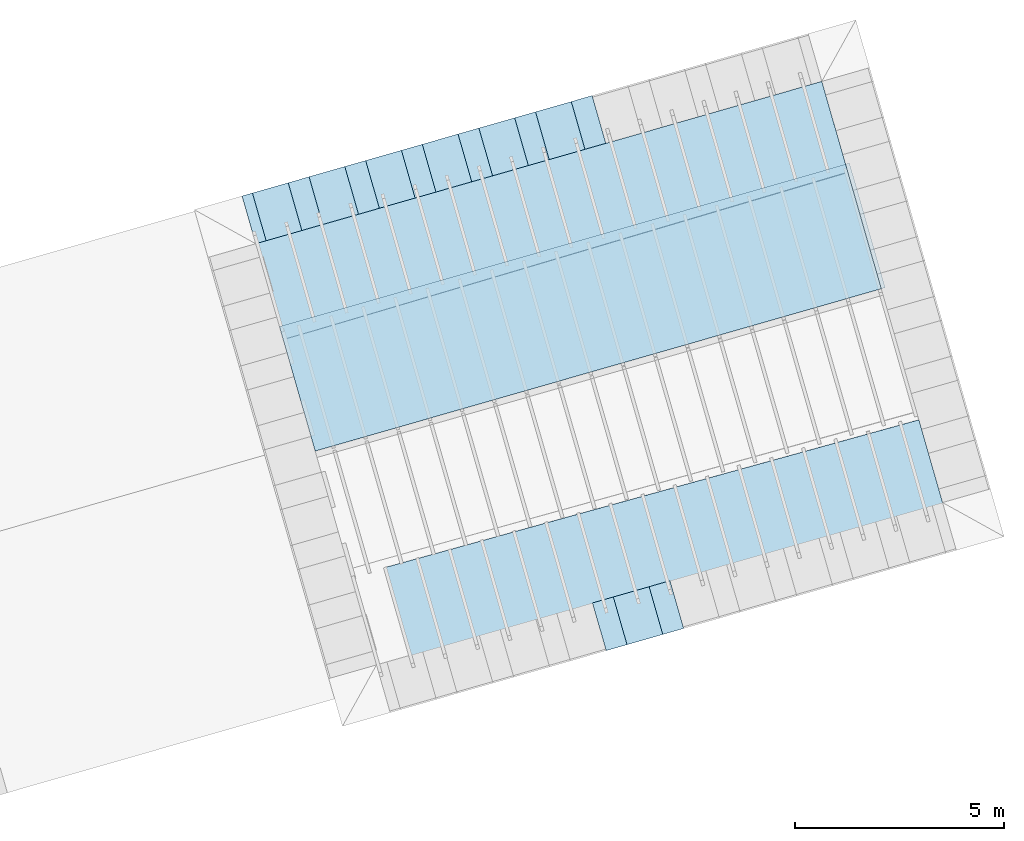
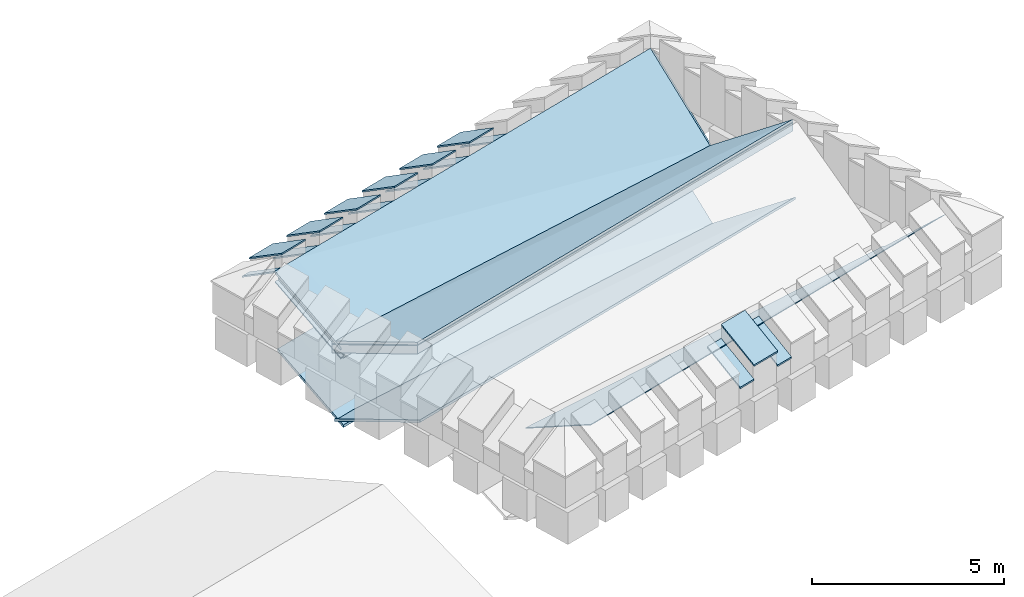
# One storey, part 2 of 10: 24 roofs.
"""IFC4 building model written with IfcOpenShell, lengths in metres."""

from ifc_helpers import new_model, entity, si_unit, converted_unit, derived_unit, direction, frame, origin_with_axes, place, context, subcontext, project, spatial, polygons, material, type_object, element, save


model = new_model("IFC4")

# Units and contexts
model_context = context("Model", 3, precision=1e-05, world=origin_with_axes(), true_north=direction((0.0, 1.0)))
body_context = subcontext(model_context, "Body", "Model", "MODEL_VIEW")
ifc_project = project(units=[si_unit("LENGTHUNIT", "METRE"), si_unit("AREAUNIT", "SQUARE_METRE"), si_unit("VOLUMEUNIT", "CUBIC_METRE"), converted_unit("PLANEANGLEUNIT", "DEGREE", entity("IfcPlaneAngleMeasure", 0.0174532925199433), si_unit("PLANEANGLEUNIT", "RADIAN"), dimensions=[0, 0, 0, 0, 0, 0, 0]), converted_unit("TIMEUNIT", "Year", entity("IfcTimeMeasure", 31557600.0), si_unit("TIMEUNIT", "SECOND"), dimensions=[0, 0, 1, 0, 0, 0, 0]), si_unit("MASSUNIT", "GRAM", prefix="KILO"), si_unit("THERMODYNAMICTEMPERATUREUNIT", "DEGREE_CELSIUS"), si_unit("LUMINOUSINTENSITYUNIT", "LUMEN"), si_unit("ENERGYUNIT", "JOULE", prefix="MEGA"), derived_unit("THERMALCONDUCTANCEUNIT", [(si_unit("POWERUNIT", "WATT"), 1), (si_unit("LENGTHUNIT", "METRE"), -1), (si_unit("THERMODYNAMICTEMPERATUREUNIT", "KELVIN"), -1)]), derived_unit("SPECIFICHEATCAPACITYUNIT", [(si_unit("ENERGYUNIT", "JOULE"), 1), (si_unit("MASSUNIT", "GRAM", prefix="KILO"), -1), (si_unit("THERMODYNAMICTEMPERATUREUNIT", "KELVIN"), -1)]), derived_unit("MASSDENSITYUNIT", [(si_unit("MASSUNIT", "GRAM", prefix="KILO"), 1), (si_unit("VOLUMEUNIT", "CUBIC_METRE"), -1)])], contexts=[model_context])

# Site, building, storey
site_placement = place(None, frame((0.0, 0.0, 0.0), z_axis=(0.0, 0.0, 1.0), x_axis=(0.9612616959383189, 0.2756373558169991, 0.0)))
site = spatial("IfcSite", under=ifc_project, at=site_placement, CompositionType="ELEMENT")
building_placement = place(site_placement, origin_with_axes())
building = spatial("IfcBuilding", under=site, at=building_placement, CompositionType="ELEMENT")
storey_placement = place(building_placement, frame((0.0, 0.0, 11.0), z_axis=(0.0, 0.0, 1.0), x_axis=(1.0, 0.0, 0.0)))
storey = spatial("IfcBuildingStorey", under=building, at=storey_placement, Name="Dach", CompositionType="ELEMENT", Elevation=11.0)

# Roofs
ifc_material_1 = material(Name="schwarz")
roof_type_1 = type_object("IfcRoofType", Name="schwarz 43", PredefinedType="NOTDEFINED")
roof_1_placement = place(storey_placement, frame((17.51182302562153, 19.30664613480766, 1.213699999999999), z_axis=(0.0, 0.0, 1.0), x_axis=(-1.0, 0.0, 0.0)))
element("IfcRoof", 1, at=roof_1_placement, inside=storey, type_object=roof_type_1, material=ifc_material_1, Name="Dach-057", PredefinedType="NOTDEFINED", context=body_context, shape_type="Tessellation", body=[
    polygons([(0.8900025616952547, -0.03772698703644295, 0.0271446603798573), (0.8900025616952547, 1.149999999999999, 0.7466800857374327), (0.0, 1.149999999999999, 0.7466800857374327), (0.0, -0.03772698703644295, 0.0271446603798573), (0.8900025620847707, -0.03772698691103216, -0.0228553396740967), (0.8900025620847707, 1.150000000333105, 0.6966800858093016), (3.516440472139948e-10, 1.150000000333105, 0.6966800858093016), (3.516440472139948e-10, -0.03772698691103216, -0.0228553396740967)], [[[1, 2, 3, 4]], [[2, 1, 5, 6]], [[3, 2, 6, 7]], [[4, 3, 7, 8]], [[1, 4, 8, 5]], [[6, 5, 8, 7]]], closed=True),
])
roof_2_placement = place(storey_placement, frame((18.92078377575579, 19.30664613818553, 1.213699999999999), z_axis=(0.0, 0.0, 1.0), x_axis=(-1.0, 0.0, 0.0)))
element("IfcRoof", 2, at=roof_2_placement, inside=storey, type_object=roof_type_1, material=ifc_material_1, Name="Dach-057", PredefinedType="NOTDEFINED", context=body_context, shape_type="Tessellation", body=[
    polygons([(0.8900025616952547, -0.03772698703644295, 0.02714466037985908), (0.8900025616952547, 1.149999999999995, 0.7466800857374345), (0.0, 1.149999999999995, 0.7466800857374345), (0.0, -0.03772698703644295, 0.02714466037985908), (0.8900025620847707, -0.03772698691103571, -0.0228553396740967), (0.8900025620847707, 1.150000000333101, 0.6966800858093034), (3.516440472139948e-10, 1.150000000333101, 0.6966800858093034), (3.516440472139948e-10, -0.03772698691103571, -0.0228553396740967)], [[[1, 2, 3, 4]], [[2, 1, 5, 6]], [[3, 2, 6, 7]], [[4, 3, 7, 8]], [[1, 4, 8, 5]], [[6, 5, 8, 7]]], closed=True),
])
roof_3_placement = place(storey_placement, frame((20.32974452589005, 19.30664614156338, 1.213699999999999), z_axis=(0.0, 0.0, 1.0), x_axis=(-1.0, 0.0, 0.0)))
element("IfcRoof", 3, at=roof_3_placement, inside=storey, type_object=roof_type_1, material=ifc_material_1, Name="Dach-057", PredefinedType="NOTDEFINED", context=body_context, shape_type="Tessellation", body=[
    polygons([(0.8900025616952547, -0.03772698703645361, 0.02714466037985019), (0.8900025616952547, 1.149999999999999, 0.7466800857374309), (0.0, 1.149999999999999, 0.7466800857374309), (0.0, -0.03772698703644295, 0.02714466037985552), (0.8900025620847707, -0.03772698691103571, -0.02285533967410025), (0.8900025620847707, 1.150000000333105, 0.6966800858093016), (3.516440472139948e-10, 1.150000000333105, 0.6966800858093016), (3.516440472139948e-10, -0.03772698691103571, -0.02285533967410025)], [[[1, 2, 3, 4]], [[2, 1, 5, 6]], [[3, 2, 6, 7]], [[4, 3, 7, 8]], [[1, 4, 8, 5]], [[6, 5, 8, 7]]], closed=True),
])
roof_4_placement = place(storey_placement, frame((21.73870527602431, 19.30664614494125, 1.213699999999999), z_axis=(0.0, 0.0, 1.0), x_axis=(-1.0, 0.0, 0.0)))
element("IfcRoof", 4, at=roof_4_placement, inside=storey, type_object=roof_type_1, material=ifc_material_1, Name="Dach-057", PredefinedType="NOTDEFINED", context=body_context, shape_type="Tessellation", body=[
    polygons([(0.8900025616952547, -0.03772698703645005, 0.02714466037985019), (0.8900025616952547, 1.149999999999999, 0.7466800857374292), (0.0, 1.149999999999999, 0.7466800857374292), (0.0, -0.03772698703644295, 0.02714466037985375), (0.8900025620847707, -0.03772698691103216, -0.02285533967410025), (0.8900025620847707, 1.150000000333101, 0.6966800858092999), (3.516440472139948e-10, 1.150000000333101, 0.6966800858092999), (3.516440472139948e-10, -0.03772698691103216, -0.02285533967410025)], [[[1, 2, 3, 4]], [[2, 1, 5, 6]], [[3, 2, 6, 7]], [[4, 3, 7, 8]], [[1, 4, 8, 5]], [[6, 5, 8, 7]]], closed=True),
])
roof_5_placement = place(storey_placement, frame((24.55662677629282, 19.30664615169697, 1.213699999999999), z_axis=(0.0, 0.0, 1.0), x_axis=(-1.0, 0.0, 0.0)))
element("IfcRoof", 5, at=roof_5_placement, inside=storey, type_object=roof_type_1, material=ifc_material_1, Name="Dach-057", PredefinedType="NOTDEFINED", context=body_context, shape_type="Tessellation", body=[
    polygons([(0.8900025616952547, -0.0377269870364465, 0.02714466037985375), (0.8900025616952547, 1.149999999999995, 0.7466800857374309), (0.0, 1.149999999999995, 0.7466800857374309), (0.0, -0.0377269870364465, 0.02714466037985375), (0.8900025620847707, -0.03772698691103571, -0.02285533967410025), (0.8900025620847707, 1.150000000333101, 0.6966800858092999), (3.516440472139948e-10, 1.150000000333101, 0.6966800858092999), (3.516440472139948e-10, -0.03772698691103571, -0.02285533967410025)], [[[1, 2, 3, 4]], [[2, 1, 5, 6]], [[3, 2, 6, 7]], [[4, 3, 7, 8]], [[1, 4, 8, 5]], [[6, 5, 8, 7]]], closed=True),
])
roof_6_placement = place(storey_placement, frame((23.14766602615857, 19.30664614831911, 1.213699999999999), z_axis=(0.0, 0.0, 1.0), x_axis=(-1.0, 0.0, 0.0)))
element("IfcRoof", 6, at=roof_6_placement, inside=storey, type_object=roof_type_1, material=ifc_material_1, Name="Dach-057", PredefinedType="NOTDEFINED", context=body_context, shape_type="Tessellation", body=[
    polygons([(0.8900025616952547, -0.03772698703645361, 0.02714466037985375), (0.8900025616952547, 1.149999999999995, 0.7466800857374345), (0.0, 1.149999999999995, 0.7466800857374345), (0.0, -0.03772698703644295, 0.02714466037985908), (0.8900025620847707, -0.03772698691103571, -0.0228553396740967), (0.8900025620847707, 1.150000000333101, 0.6966800858093052), (3.516440472139948e-10, 1.150000000333101, 0.6966800858093052), (3.516440472139948e-10, -0.03772698691103571, -0.0228553396740967)], [[[1, 2, 3, 4]], [[2, 1, 5, 6]], [[3, 2, 6, 7]], [[4, 3, 7, 8]], [[1, 4, 8, 5]], [[6, 5, 8, 7]]], closed=True),
])
roof_7_placement = place(storey_placement, frame((22.25766380442423, 6.52540147175251, 1.213699999999999), z_axis=(0.0, 0.0, 1.0), x_axis=(1.0, 0.0, 0.0)))
element("IfcRoof", 7, at=roof_7_placement, inside=storey, type_object=roof_type_1, material=ifc_material_1, Name="Dach-057", PredefinedType="NOTDEFINED", context=body_context, shape_type="Tessellation", body=[
    polygons([(0.8900025616952547, -0.03772698703644295, 0.0271446603798573), (0.8900025616952547, 1.149999999999999, 0.7466800857374345), (0.0, 1.15, 0.7466800857374345), (0.0, -0.03772698703644295, 0.0271446603798573), (0.8900025620847707, -0.03772698691103127, -0.02285533967409492), (0.8900025620847707, 1.150000000333108, 0.6966800858093052), (3.516440472139948e-10, 1.150000000333108, 0.6966800858093052), (3.516440472139948e-10, -0.03772698691103127, -0.02285533967409492)], [[[1, 2, 3, 4]], [[2, 1, 5, 6]], [[3, 2, 6, 7]], [[4, 3, 7, 8]], [[1, 4, 8, 5]], [[6, 5, 8, 7]]], closed=True),
])
roof_8_placement = place(storey_placement, frame((25.07558374405819, 19.28865915716659, 0.7745999999999995), z_axis=(0.0, 0.0, 1.0), x_axis=(-1.0, 0.0, 0.0)))
element("IfcRoof", 8, at=roof_8_placement, inside=storey, type_object=roof_type_1, material=ifc_material_1, Name="Dach-048", PredefinedType="NOTDEFINED", context=body_context, shape_type="Tessellation", body=[
    polygons([(0.5189582746531372, -0.05571398314985743, 0.01624798038468001), (0.51895827465313, 1.132013003886584, 0.7357834057422554), (0.0, 1.132013003886584, 0.7357834057422554), (0.0, -0.05571398314986808, 0.01624798038467468), (0.5189582750426531, -0.05571398302445019, -0.03375201966927577), (0.5189582750426531, 1.13201300421969, 0.6857834058141261), (-1.637339153148787e-10, 1.13201300421969, 0.6857834058141261), (-1.637339153148787e-10, -0.05571398302445019, -0.03375201966927577)], [[[1, 2, 3, 4]], [[2, 1, 5, 6]], [[3, 2, 6, 7]], [[4, 3, 7, 8]], [[1, 4, 8, 5]], [[6, 5, 8, 7]]], closed=True),
])
roof_9_placement = place(storey_placement, frame((23.66662232820861, 19.28865915357091, 0.7745999999999995), z_axis=(0.0, 0.0, 1.0), x_axis=(-1.0, 0.0, 0.0)))
element("IfcRoof", 9, at=roof_9_placement, inside=storey, type_object=roof_type_1, material=ifc_material_1, Name="Dach-048", PredefinedType="NOTDEFINED", context=body_context, shape_type="Tessellation", body=[
    polygons([(0.5189582746531372, -0.05571398314986098, 0.01624798038468001), (0.51895827465313, 1.132013003886584, 0.735783405742259), (0.0, 1.132013003886584, 0.735783405742259), (0.0, -0.05571398314986098, 0.01624798038468001), (0.5189582750426531, -0.05571398302445019, -0.03375201966927399), (0.5189582750426531, 1.13201300421969, 0.6857834058141279), (-1.637339153148787e-10, 1.13201300421969, 0.6857834058141279), (-1.637339153148787e-10, -0.05571398302445019, -0.03375201966927399)], [[[1, 2, 3, 4]], [[2, 1, 5, 6]], [[3, 2, 6, 7]], [[4, 3, 7, 8]], [[1, 4, 8, 5]], [[6, 5, 8, 7]]], closed=True),
])
roof_10_placement = place(storey_placement, frame((20.84869949650946, 19.28865914637954, 0.7745999999999995), z_axis=(0.0, 0.0, 1.0), x_axis=(-1.0, 0.0, 0.0)))
element("IfcRoof", 10, at=roof_10_placement, inside=storey, type_object=roof_type_1, material=ifc_material_1, Name="Dach-048", PredefinedType="NOTDEFINED", context=body_context, shape_type="Tessellation", body=[
    polygons([(0.5189582746531372, -0.05571398314985743, 0.01624798038468356), (0.51895827465313, 1.132013003886584, 0.7357834057422625), (0.0, 1.132013003886584, 0.7357834057422625), (0.0, -0.05571398314986453, 0.01624798038468001), (0.5189582750426531, -0.05571398302445019, -0.03375201966927044), (0.5189582750426531, 1.13201300421969, 0.6857834058141314), (-1.637339153148787e-10, 1.13201300421969, 0.6857834058141314), (-1.637339153148787e-10, -0.05571398302445019, -0.03375201966927044)], [[[1, 2, 3, 4]], [[2, 1, 5, 6]], [[3, 2, 6, 7]], [[4, 3, 7, 8]], [[1, 4, 8, 5]], [[6, 5, 8, 7]]], closed=True),
])
roof_11_placement = place(storey_placement, frame((22.25766091235904, 19.28865914997523, 0.7745999999999995), z_axis=(0.0, 0.0, 1.0), x_axis=(-1.0, 0.0, 0.0)))
element("IfcRoof", 11, at=roof_11_placement, inside=storey, type_object=roof_type_1, material=ifc_material_1, Name="Dach-048", PredefinedType="NOTDEFINED", context=body_context, shape_type="Tessellation", body=[
    polygons([(0.5189582746531372, -0.05571398314985743, 0.01624798038467823), (0.51895827465313, 1.132013003886584, 0.7357834057422572), (0.0, 1.132013003886584, 0.7357834057422572), (0.0, -0.05571398314985743, 0.01624798038467823), (0.5189582750426531, -0.05571398302445019, -0.03375201966927577), (0.5189582750426531, 1.13201300421969, 0.6857834058141261), (-1.637339153148787e-10, 1.13201300421969, 0.6857834058141261), (-1.637339153148787e-10, -0.05571398302445019, -0.03375201966927577)], [[[1, 2, 3, 4]], [[2, 1, 5, 6]], [[3, 2, 6, 7]], [[4, 3, 7, 8]], [[1, 4, 8, 5]], [[6, 5, 8, 7]]], closed=True),
])
roof_12_placement = place(storey_placement, frame((18.03077666481031, 19.28865913918818, 0.7745999999999995), z_axis=(0.0, 0.0, 1.0), x_axis=(-1.0, 0.0, 0.0)))
element("IfcRoof", 12, at=roof_12_placement, inside=storey, type_object=roof_type_1, material=ifc_material_1, Name="Dach-048", PredefinedType="NOTDEFINED", context=body_context, shape_type="Tessellation", body=[
    polygons([(0.5189582746531372, -0.05571398314985743, 0.01624798038468001), (0.51895827465313, 1.132013003886584, 0.7357834057422572), (0.0, 1.132013003886584, 0.7357834057422572), (0.0, -0.05571398314985743, 0.01624798038468001), (0.5189582750426531, -0.05571398302444663, -0.03375201966927399), (0.5189582750426531, 1.13201300421969, 0.6857834058141261), (-1.637339153148787e-10, 1.13201300421969, 0.6857834058141261), (-1.637339153148787e-10, -0.05571398302444663, -0.03375201966927399)], [[[1, 2, 3, 4]], [[2, 1, 5, 6]], [[3, 2, 6, 7]], [[4, 3, 7, 8]], [[1, 4, 8, 5]], [[6, 5, 8, 7]]], closed=True),
])
roof_13_placement = place(storey_placement, frame((16.62182124404158, 19.28865913535804, 0.7745999999999995), z_axis=(0.0, 0.0, 1.0), x_axis=(-1.0, 0.0, 0.0)))
element("IfcRoof", 13, at=roof_13_placement, inside=storey, type_object=roof_type_1, material=ifc_material_1, Name="Dach-048", PredefinedType="NOTDEFINED", context=body_context, shape_type="Tessellation", body=[
    polygons([(0.2589616170426829, -0.05571398314985743, 0.01624798038467823), (0.2589616170427114, 1.132013003886588, 0.7357834057422572), (0.0, 1.132013003886595, 0.7357834057422608), (0.0, -0.05571398314985032, 0.01624798038468178), (0.2589616174322273, -0.05571398302443953, -0.03375201966927222), (0.2589616174322309, 1.132013004219697, 0.6857834058141297), (4.169287137756328e-10, 1.132013004219697, 0.6857834058141297), (4.16925161061954e-10, -0.05571398302443953, -0.03375201966927222)], [[[1, 2, 3, 4]], [[2, 1, 5, 6]], [[3, 2, 6, 7]], [[4, 3, 7, 8]], [[1, 4, 8, 5]], [[6, 5, 8, 7]]], closed=True),
])
roof_14_placement = place(storey_placement, frame((19.43973808065989, 19.28865914278386, 0.7745999999999995), z_axis=(0.0, 0.0, 1.0), x_axis=(-1.0, 0.0, 0.0)))
element("IfcRoof", 14, at=roof_14_placement, inside=storey, type_object=roof_type_1, material=ifc_material_1, Name="Dach-048", PredefinedType="NOTDEFINED", context=body_context, shape_type="Tessellation", body=[
    polygons([(0.5189582746531372, -0.05571398314985743, 0.01624798038468178), (0.51895827465313, 1.132013003886581, 0.735783405742259), (0.0, 1.132013003886581, 0.735783405742259), (0.0, -0.05571398314986453, 0.01624798038467823), (0.5189582750426531, -0.05571398302444663, -0.03375201966927222), (0.5189582750426531, 1.132013004219687, 0.6857834058141279), (-1.637339153148787e-10, 1.132013004219687, 0.6857834058141279), (-1.637339153148787e-10, -0.05571398302444663, -0.03375201966927222)], [[[1, 2, 3, 4]], [[2, 1, 5, 6]], [[3, 2, 6, 7]], [[4, 3, 7, 8]], [[1, 4, 8, 5]], [[6, 5, 8, 7]]], closed=True),
])
roof_15_placement = place(storey_placement, frame((23.1476663661116, 6.543388469605022, 0.7745999999999995), z_axis=(0.0, 0.0, 1.0), x_axis=(1.0, 0.0, 0.0)))
element("IfcRoof", 15, at=roof_15_placement, inside=storey, type_object=roof_type_1, material=ifc_material_1, Name="Dach-048", PredefinedType="NOTDEFINED", context=body_context, shape_type="Tessellation", body=[
    polygons([(0.5189582746531372, -0.05571398314985565, 0.01624798038468178), (0.51895827465313, 1.132013003886587, 0.735783405742259), (0.0, 1.132013003886583, 0.7357834057422572), (0.0, -0.0557139831498592, 0.01624798038468001), (0.5189582750426531, -0.05571398302444575, -0.03375201966927222), (0.5189582750426531, 1.132013004219694, 0.6857834058141297), (-1.637339153148787e-10, 1.132013004219694, 0.6857834058141297), (-1.637339153148787e-10, -0.05571398302444575, -0.03375201966927222)], [[[1, 2, 3, 4]], [[2, 1, 5, 6]], [[3, 2, 6, 7]], [[4, 3, 7, 8]], [[1, 4, 8, 5]], [[6, 5, 8, 7]]], closed=True),
])
roof_16_placement = place(storey_placement, frame((21.73870552978095, 6.543388466126831, 0.7745999999999995), z_axis=(0.0, 0.0, 1.0), x_axis=(1.0, 0.0, 0.0)))
element("IfcRoof", 16, at=roof_16_placement, inside=storey, type_object=roof_type_1, material=ifc_material_1, Name="Dach-048", PredefinedType="NOTDEFINED", context=body_context, shape_type="Tessellation", body=[
    polygons([(0.5189582746531372, -0.05571398314985654, 0.01624798038468178), (0.51895827465313, 1.132013003886586, 0.7357834057422572), (0.0, 1.132013003886584, 0.7357834057422572), (0.0, -0.05571398314985743, 0.01624798038468001), (0.5189582750426531, -0.05571398302444575, -0.03375201966927222), (0.5189582750426531, 1.132013004219693, 0.6857834058141279), (-1.637339153148787e-10, 1.132013004219693, 0.6857834058141279), (-1.637339153148787e-10, -0.05571398302444575, -0.03375201966927222)], [[[1, 2, 3, 4]], [[2, 1, 5, 6]], [[3, 2, 6, 7]], [[4, 3, 7, 8]], [[1, 4, 8, 5]], [[6, 5, 8, 7]]], closed=True),
])
ifc_material_2 = material(Name="Mineralwolle 2")
roof_type_2 = type_object("IfcRoofType", Name="Mineralwolle 2", PredefinedType="NOTDEFINED")
roof_17_placement = place(storey_placement, frame((-32.55337325096843, 25.68336648703179, -11.3285), z_axis=(0.0, 0.0, 1.0), x_axis=(-1.0, 0.0, 0.0)))
element("IfcRoof", 17, at=roof_17_placement, inside=storey, type_object=roof_type_2, material=ifc_material_2, Name="Dach-005", PredefinedType="NOTDEFINED", context=body_context, shape_type="Tessellation", body=[
    polygons([(-49.01725441794425, 7.526717329425702, 12.48631507876694), (-49.01725441792901, 9.910453348801425, 11.21814811817108), (-48.91623288382571, 9.910453172159267, 11.21814778614168), (-48.91623288384299, 7.526717152783544, 12.48631474673754), (-49.01725451101589, 7.526717329411352, 12.4579973204252), (-49.01725451100065, 9.910453347828417, 11.18983036033935), (-49.8324206073811, 9.910454773188107, 11.18983303956076), (-49.83242051430775, 9.910454774161114, 11.21815079739249), (-49.83242040261973, 9.910454775328724, 11.25213210623356), (-49.83241980695028, 9.91045478155597, 11.43336575338594), (-49.83241969526226, 9.910454782723578, 11.46734706146747), (-49.03241898094629, 9.91045338387622, 11.46734443209037), (-49.03241898226052, 9.910453382710594, 11.43336312400852), (-49.03241957791901, 9.910453376483346, 11.25212947685614), (-48.91623277213974, 9.910453173326877, 11.25212909498275), (-48.91623277215702, 7.526717152800764, 12.52029605619062), (-49.03241957794302, 7.526717355957235, 12.52029643806402), (-49.03241898228453, 7.526717356049073, 12.70153008848049), (-49.03241898093739, 7.526717356064312, 12.73551139717435), (-49.8324196952554, 7.526718754911668, 12.73551402655145), (-63.12090365273619, 7.526718754870632, 12.73557008008085), (-63.12090365273619, 7.526718754841101, 12.70158877139339), (-63.12090365273619, 7.526718754683602, 12.52035512100934), (-63.12090365273619, 7.526718754654071, 12.48637381156233), (-63.12090365273619, 7.52671875463898, 12.46900952098939), (-63.12090365273619, 7.526718754637136, 12.4668871827851), (-63.12090365273619, 7.526718754629461, 12.45805605322565), (-49.83242060735748, 7.526718754771042, 12.4579999996466), (-63.12094079620453, 9.792009235594925, 10.21349250680425), (-63.12094079620453, 9.792009235600363, 10.21456624115422), (-63.12094078538213, 9.79134920367899, 10.24939116692629), (-63.12094078538213, 9.791349203685257, 10.25067014409473), (-63.1209407710363, 9.790474286034227, 10.29828079400867), (-63.1209407710363, 9.790474286065868, 10.30503481464133), (-63.12094069983237, 9.786131729514391, 10.58146161552495), (-63.12094069983237, 9.786131729518738, 10.5826654639523), (-63.12093931522156, 9.701687658855539, 10.65523738074027), (-63.12093931417802, 9.701624016414732, 10.2615782948578), (-63.12093986320171, 9.735107645063142, 10.24376468899331), (-63.12094034315177, 9.764378641093067, 10.22819224336584), (-63.12094069289841, 9.785708844818, 10.61053733035394)], [[[1, 2, 3, 4]], [[5, 6, 2, 1]], [[2, 6, 7, 8, 9, 10, 11, 12, 13, 14, 15, 3]], [[4, 3, 15, 16]], [[4, 16, 17, 18, 19, 20, 21, 22, 23, 24, 25, 26, 27, 28, 5, 1]], [[5, 28, 7, 6]], [[7, 29, 30, 8]], [[8, 31, 32, 9]], [[10, 9, 33, 34]], [[10, 35, 36, 11]], [[12, 11, 20, 19]], [[18, 13, 12, 19]], [[17, 14, 13, 18]], [[16, 15, 14, 17]], [[20, 37, 21]], [[27, 38, 28]], [[28, 38, 39, 40, 29, 7]], [[31, 8, 30]], [[9, 32, 33]], [[34, 35, 10]], [[11, 36, 41]], [[41, 37, 20, 11]]], closed=False),
    polygons([(-62.980048980997, 9.755524186557253, 10.49244476836244), (-63.00638124672686, 9.759788486013356, 10.20362950782021), (-62.89257694422515, 7.500677341807842, 12.46262865117778), (-63.12094029361833, 9.76135771628415, 10.50537643753256), (-63.12094034315177, 9.764378641093067, 10.22819224336584), (-63.12094034566218, 9.764531744463378, 10.21414428222537), (-63.12093986320171, 9.735107645063142, 10.24376468899331), (-63.12090365273619, 7.526718754637136, 12.4668871827851), (-63.12090338075168, 7.510131076251311, 12.48358552839767), (-63.12090365273619, 7.52671875463898, 12.46900952098939)], [[[1, 2, 3]], [[2, 1, 4, 5, 6]], [[3, 2, 6, 7, 8, 9]], [[9, 10, 4, 1, 3]]], closed=False),
])
roof_18_placement = place(storey_placement, frame((-32.66955932187452, 25.68336348688057, -11.32750233411046), z_axis=(0.0, 0.0, 1.0), x_axis=(-1.0, 0.0, 0.0)))
element("IfcRoof", 18, at=roof_18_placement, inside=storey, type_object=roof_type_2, material=ifc_material_2, Name="Dach-005", PredefinedType="NOTDEFINED", context=body_context, shape_type="Tessellation", body=[
    polygons([(-49.03241895488413, 7.526717356106333, 12.82046467080795), (-49.03241895484933, 9.910453386794217, 11.55229770419392), (-49.03241894872675, 9.910453387766449, 11.58061546156172), (-49.0324189487643, 7.526717356119908, 12.84878242868575), (-49.03241914102741, 7.526717356077633, 12.7638291550528), (-49.03241914099262, 9.910453384848202, 11.4956621894588), (-49.83241960218891, 9.910454783696586, 11.49566481883503), (-49.83241941604221, 9.910454785642601, 11.55230033357015), (-49.83241932296885, 9.910454786615608, 11.5806180909377), (-49.83241932296885, 7.526718754969067, 12.84878505806174), (-63.12090365273619, 7.526718754969069, 12.84884111157088), (-63.12090365273619, 7.52671875494446, 12.82052335369838), (-63.12090365273619, 7.526718754895241, 12.76388783795336), (-49.83241960218377, 7.526718754926017, 12.76383178442902), (-63.12094068535443, 9.785248754882375, 10.64274957000672), (-63.12094068535443, 9.785248754889109, 10.64473479342037), (-63.12094067203195, 9.784436249590497, 10.70310824331149), (-63.12094067203195, 9.784436249593634, 10.70409110526153), (-63.1209406639095, 9.783940881024098, 10.74073409211993), (-63.12093931551461, 9.701705531299408, 10.78448405943876), (-63.12093931529781, 9.701692308706782, 10.68720237413882)], [[[1, 2, 3, 4]], [[5, 6, 2, 1]], [[6, 7, 8, 9, 3, 2]], [[4, 3, 9, 10]], [[1, 4, 10, 11, 12, 13, 14, 5]], [[5, 14, 7, 6]], [[7, 15, 16, 8]], [[8, 17, 18, 9]], [[9, 19, 20, 10]], [[10, 20, 11]], [[13, 21, 14]], [[21, 15, 7, 14]], [[8, 16, 17]], [[9, 18, 19]]], closed=False),
])
roof_19_placement = place(storey_placement, frame((79.48357609601396, -0.05216609558188946, -11.32434781702759), z_axis=(0.0, 0.0, 1.0), x_axis=(0.9999999998501536, -1.731163750856407e-05, 0.0)))
element("IfcRoof", 19, at=roof_19_placement, inside=storey, type_object=roof_type_2, material=ifc_material_2, Name="Dach-004", PredefinedType="NOTDEFINED", context=body_context, shape_type="Tessellation", body=[
    polygons([(-49.03242135674516, 13.04734108985332, 12.9502049427386), (-49.03242001087519, 16.14734106880072, 10.53748664567232), (-49.03242003992625, 16.14734106686427, 10.56989730110458), (-49.03242088729235, 13.04734108982853, 12.98339928620701), (-49.03242386049353, 13.04734108998552, 12.77316844028338), (-49.03241965870473, 16.14734108408878, 10.2903223522107), (-63.12099309865152, 16.1473410897108, 11.48229899732354), (-63.12099262925499, 16.1473410897189, 11.51549334077637), (-63.12099264494729, 13.04734108964386, 12.98364324252603), (-63.12099311436385, 13.04734108961325, 12.95044889908386), (-49.03242432994634, 13.04734109001031, 12.73997409607302), (-49.03241946195322, 16.14734108754209, 10.2428083424142), (-63.12099560209978, 16.14734108966761, 11.30526249495138), (-63.12099561791889, 13.04734108944999, 12.77341239676856), (-63.12099608733546, 13.04734108941938, 12.74021805258444), (-49.03242472115704, 13.04734109003097, 12.71231214211098), (-49.03241932300207, 16.1473410897459, 10.2134361772507), (-63.12099607149633, 16.14734108965951, 11.2720681507566), (-63.12099647851595, 13.04734108939387, 12.71255609864426), (-63.12099646266012, 16.14734108965276, 11.24440619680753)], [[[1, 2, 3, 4]], [[5, 6, 2, 1]], [[2, 7, 8, 3]], [[3, 8, 4]], [[4, 9, 10, 1]], [[5, 11, 12, 6]], [[6, 13, 7, 2]], [[1, 10, 14, 5]], [[10, 9, 8, 7]], [[4, 8, 9]], [[5, 14, 15, 11]], [[12, 11, 16, 17]], [[12, 18, 13, 6]], [[14, 10, 7, 13]], [[13, 18, 15, 14]], [[11, 15, 19, 16]], [[16, 20, 17]], [[17, 20, 18, 12]], [[15, 18, 20, 19]], [[20, 16, 19]]], closed=True),
])
roof_20_placement = place(storey_placement, frame((79.48350774007132, -0.05236535147152455, -11.3285), z_axis=(0.0, 0.0, 1.0), x_axis=(0.9999999997715359, -2.137588380027057e-05, 0.0)))
element("IfcRoof", 20, at=roof_20_placement, inside=storey, type_object=roof_type_2, material=ifc_material_2, Name="Dach-004", PredefinedType="NOTDEFINED", context=body_context, shape_type="Tessellation", body=[
    polygons([(-49.03241999928466, 16.14734106500588, 10.60806260237096), (-63.12099223809119, 16.14734108972564, 11.54315529427202), (-49.03242049608168, 13.04734108980786, 13.01106123971564), (-49.03241998120958, 16.14734106699309, 10.57404948407699), (-63.12099262925499, 16.14734108971889, 11.51549334077638), (-63.12099225376681, 13.04734108966936, 13.0113051960128), (-49.03242088729236, 13.04734108982852, 12.98339928620701), (-63.12099264494729, 13.04734108964385, 12.98364324252603)], [[[1, 2, 3]], [[4, 5, 2, 1]], [[3, 2, 6]], [[7, 4, 1, 3]], [[7, 5, 4]], [[2, 5, 8, 6]], [[3, 6, 8, 7]], [[8, 5, 7]]], closed=True),
])
roof_21_placement = place(storey_placement, frame((79.48385227220211, -0.05131726557685234, -11.32865725006153), z_axis=(0.0, 0.0, 1.0), x_axis=(1.0, 0.0, 0.0)))
element("IfcRoof", 21, at=roof_21_placement, inside=storey, type_object=roof_type_2, material=ifc_material_2, Name="Dach-004", PredefinedType="NOTDEFINED", context=body_context, shape_type="Tessellation", body=[
    polygons([(-49.03241994442309, 16.14734105872516, 10.72350971299233), (-63.12099106459983, 16.1473410897459, 11.62614115475898), (-49.03241932244962, 13.0473410897459, 13.09404710024153), (-49.03241998149971, 16.14734106160566, 10.66971724682379), (-63.12099145576362, 16.14734108973915, 11.59847920126333), (-63.12099108022539, 13.0473410897459, 13.09429105647309), (-49.0324197136603, 13.04734108976656, 13.0663851467329), (-49.03241999928466, 16.14734106500589, 10.60806260237096), (-63.1209922380912, 16.14734108972565, 11.54315529427202), (-63.12099147140587, 13.04734108972039, 13.06662910298633), (-49.03242049608167, 13.04734108980787, 13.01106123971564), (-63.12099225376681, 13.04734108966937, 13.0113051960128)], [[[1, 2, 3]], [[4, 5, 2, 1]], [[3, 2, 6]], [[7, 4, 1, 3]], [[8, 9, 5, 4]], [[6, 2, 5, 10]], [[3, 6, 10, 7]], [[4, 7, 11, 8]], [[11, 9, 8]], [[5, 9, 12, 10]], [[7, 10, 12, 11]], [[12, 9, 11]]], closed=True),
])
roof_22_placement = place(storey_placement, frame((-32.57217368604458, 25.68341318812653, -13.84878242868575), z_axis=(0.0, 0.0, 1.0), x_axis=(-1.0, 0.0, 0.0)))
element("IfcRoof", 22, at=roof_22_placement, inside=storey, type_object=roof_type_2, material=ifc_material_2, Name="Dach-005", PredefinedType="NOTDEFINED", context=body_context, shape_type="Tessellation", body=[
    polygons([(-63.12090365273619, 7.526718754895241, 12.76388783795336), (-49.83241960218377, 7.526718754926017, 12.76383178442902), (-49.03241914102741, 7.526717356077633, 12.7638291550528), (-49.03241895488413, 7.526717356106333, 12.82046467080795), (-49.0324189487643, 7.526717356119908, 12.84878242868575), (-49.83241932296885, 7.526718754969067, 12.84878505806174), (-63.12090365273619, 7.526718754969069, 12.84884111157088), (-63.12090365273619, 7.52671875494446, 12.82052335369838), (-63.12093931529781, 9.701692308706782, 10.68720237413882), (-49.83241960218891, 9.910454783696586, 11.49566481883503), (-49.03241914099262, 9.910453384848202, 11.4956621894588), (-49.03241895484933, 9.910453386794217, 11.55229770419392), (-49.03241894872675, 9.910453387766449, 11.58061546156172), (-49.83241932296885, 9.910454786615608, 11.5806180909377), (-63.12093931551461, 9.701705531299408, 10.78448405943876), (-63.12094068535443, 9.785248754882375, 10.64274957000672), (-49.83241941604221, 9.910454785642601, 11.55230033357015), (-63.1209406639095, 9.783940881024098, 10.74073409211993), (-63.12094068535443, 9.785248754889109, 10.64473479342037), (-63.12094067203195, 9.784436249590497, 10.70310824331149), (-63.12094067203195, 9.784436249593634, 10.70409110526153)], [[[1, 2, 3, 4, 5, 6, 7, 8]], [[1, 9, 2]], [[3, 2, 10, 11]], [[3, 11, 12, 4]], [[5, 4, 12, 13]], [[14, 6, 5, 13]], [[15, 7, 6]], [[9, 16, 10, 2]], [[10, 17, 14, 13, 12, 11]], [[18, 15, 6, 14]], [[16, 19, 17, 10]], [[20, 21, 14, 17]], [[21, 18, 14]], [[19, 20, 17]]], closed=False),
])
roof_23_placement = place(storey_placement, frame((79.58114929555309, -0.05126896292304672, -13.84878242868575), z_axis=(0.0, 0.0, 1.0), x_axis=(1.0, 0.0, 0.0)))
element("IfcRoof", 23, at=roof_23_placement, inside=storey, type_object=roof_type_2, material=ifc_material_2, Name="Dach-004", PredefinedType="NOTDEFINED", context=body_context, shape_type="Tessellation", body=[
    polygons([(-49.03242049608167, 13.04734108980787, 13.01106123971564), (-63.1209922380912, 16.14734108972565, 11.54315529427202), (-49.03241999928466, 16.14734106500589, 10.60806260237096), (-63.12099225376681, 13.04734108966937, 13.0113051960128), (-63.12099145576362, 16.14734108973915, 11.59847920126333), (-49.03241998149971, 16.14734106160566, 10.66971724682379), (-49.0324197136603, 13.04734108976656, 13.0663851467329), (-63.12099147140587, 13.04734108972039, 13.06662910298633), (-63.12099106459983, 16.1473410897459, 11.62614115475898), (-49.03241994442309, 16.14734105872516, 10.72350971299233), (-49.03241932244962, 13.0473410897459, 13.09404710024153), (-63.12099108022539, 13.0473410897459, 13.09429105647309)], [[[1, 2, 3]], [[4, 2, 1]], [[2, 5, 6, 3]], [[1, 3, 6, 7]], [[8, 5, 2, 4]], [[8, 4, 1, 7]], [[6, 5, 9, 10]], [[6, 10, 11, 7]], [[8, 12, 9, 5]], [[12, 8, 7, 11]], [[10, 9, 11]], [[9, 12, 11]]], closed=True),
])
ifc_material_3 = material()
roof_type_3 = type_object("IfcRoofType", PredefinedType="NOTDEFINED")
roof_24_placement = place(storey_placement, frame((-32.66955969550476, -0.05131726657445945, -11.3285), z_axis=(0.0, 0.0, 1.0), x_axis=(1.0, 0.0, 0.0)))
element("IfcRoof", 24, at=roof_24_placement, inside=storey, type_object=roof_type_3, material=ifc_material_3, Name="Dach-005", PredefinedType="NOTDEFINED", context=body_context, shape_type="Tessellation", body=[
    polygons([(49.83241960218377, 7.526718754926017, 12.76383178442902), (49.83241969525541, 7.526718754911668, 12.73551402655145), (63.12090365273619, 7.526718754870632, 12.73557008008085), (63.12090365273619, 7.526718754895241, 12.76388783795336), (49.83241960218891, 9.910454783696586, 11.49566481883503), (49.83241969526226, 9.91045478272358, 11.46734706146747), (63.12093931522156, 9.701687658855539, 10.65523738074027), (63.12093931529781, 9.701692308706782, 10.68720237413882), (63.12094069289841, 9.785708844818, 10.61053733035394), (63.12094069289841, 9.7857088448215, 10.61153546295941), (63.12094068535443, 9.785248754882375, 10.64274957000672)], [[[1, 2, 3, 4]], [[2, 1, 5, 6]], [[3, 2, 7]], [[8, 4, 3, 7, 9, 10, 11]], [[1, 4, 8]], [[5, 1, 8, 11]], [[6, 5, 10, 9]], [[2, 6, 9, 7]], [[10, 5, 11]]], closed=True),
])

save(model, "model.ifc")
